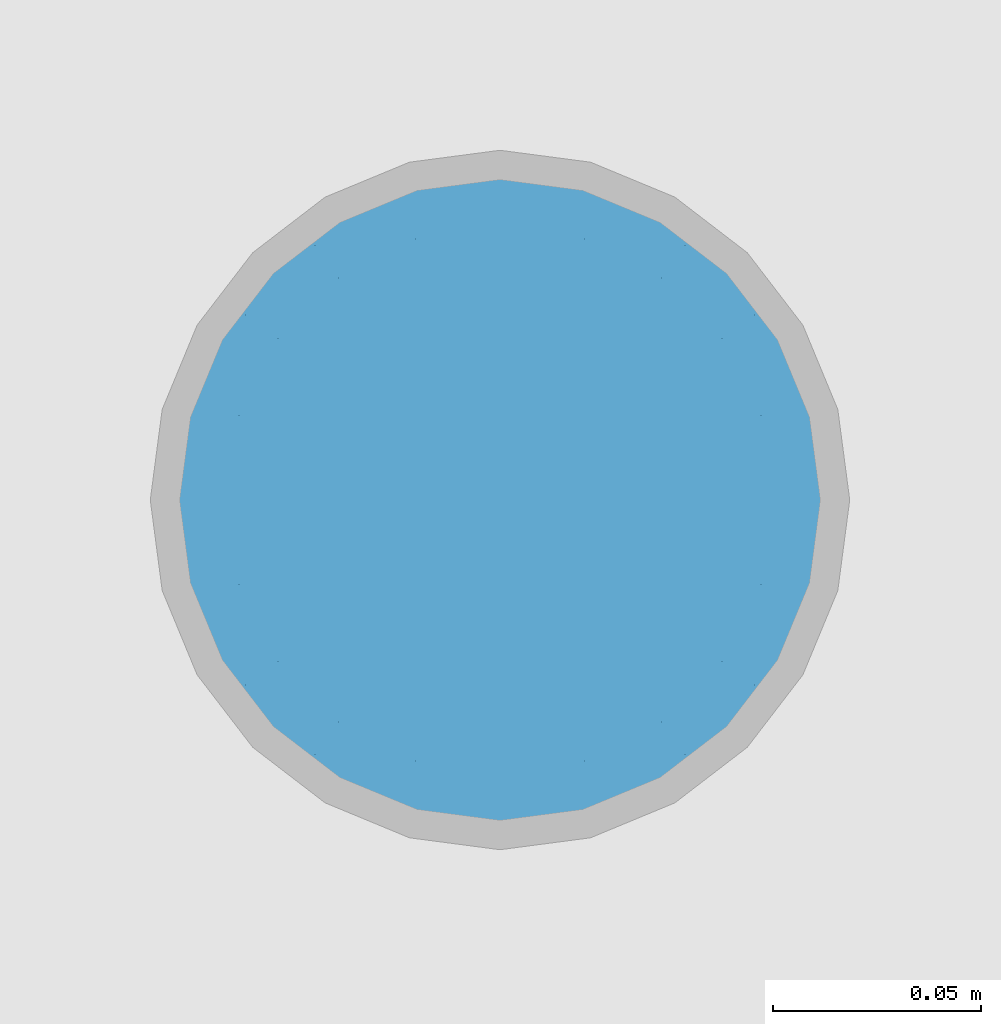
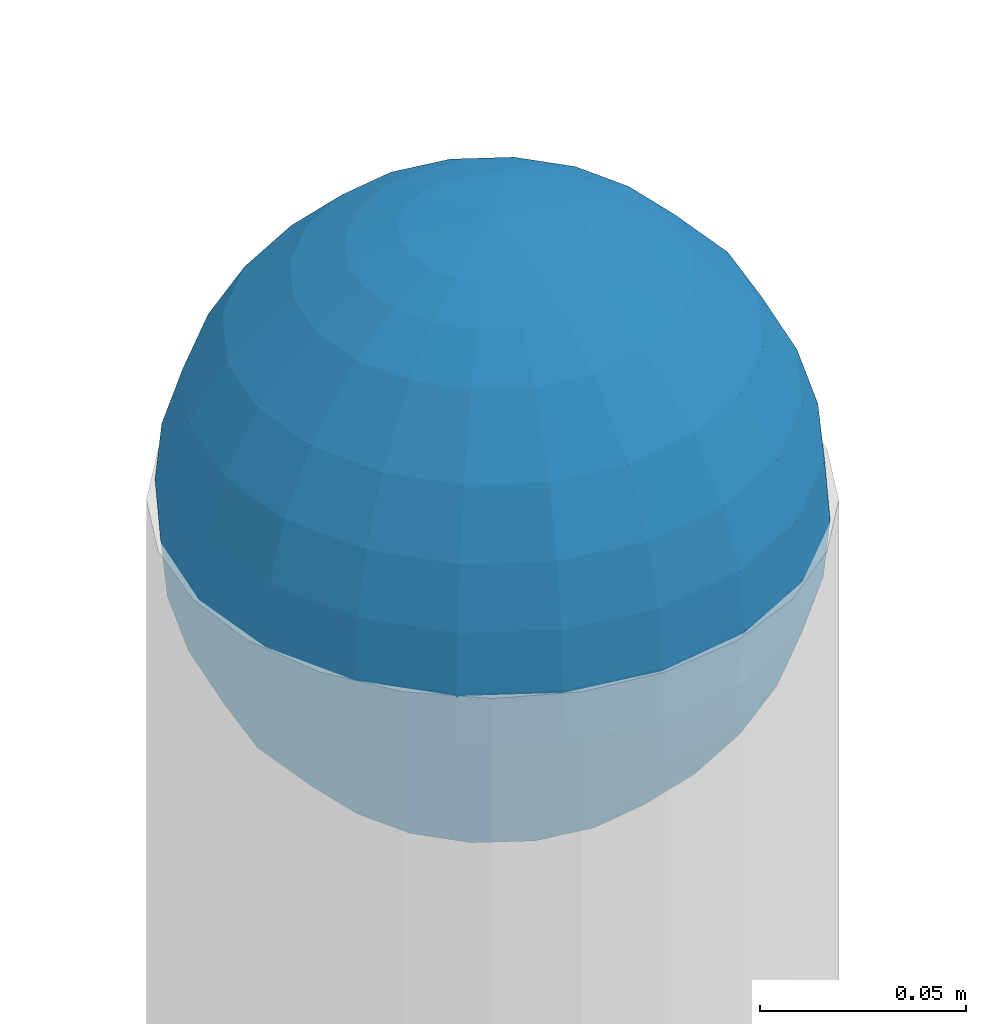
# One storey, part 1545 of 3843: 1 column, 1 element without a shape of its own.
"""IFC2X3 building model written with IfcOpenShell, lengths in millimetres."""

from ifc_helpers import new_model, si_unit, frame, origin_with_axes, place, context, subcontext, project, spatial, faceted_brep, material, type_object, element, aggregate, save


model = new_model("IFC2X3")

# Units and contexts
model_context = context("Model", 3, precision=1e-05, world=origin_with_axes())
body_context = subcontext(model_context, "Body", "Model", "MODEL_VIEW")
ifc_project = project(units=[si_unit("LENGTHUNIT", "METRE", prefix="MILLI"), si_unit("AREAUNIT", "SQUARE_METRE"), si_unit("VOLUMEUNIT", "CUBIC_METRE"), si_unit("MASSUNIT", "GRAM", prefix="KILO"), si_unit("TIMEUNIT", "SECOND"), si_unit("PLANEANGLEUNIT", "RADIAN"), si_unit("SOLIDANGLEUNIT", "STERADIAN"), si_unit("THERMODYNAMICTEMPERATUREUNIT", "DEGREE_CELSIUS"), si_unit("LUMINOUSINTENSITYUNIT", "LUMEN")], contexts=[model_context])

# Site, building, storey
site_placement = place(None, origin_with_axes())
site = spatial("IfcSite", under=ifc_project, at=site_placement, CompositionType="ELEMENT")
building_placement = place(site_placement, origin_with_axes())
building = spatial("IfcBuilding", under=site, at=building_placement, Name="Undefined", CompositionType="ELEMENT")
storey_placement = place(building_placement, origin_with_axes())
storey = spatial("IfcBuildingStorey", under=building, at=storey_placement, Name="Undefined", CompositionType="ELEMENT", Elevation=0.0)

# Assembly, column
assembly_placement = place(storey_placement, origin_with_axes())
assembly = element("IfcElementAssembly", 1, at=assembly_placement, inside=storey, Name="CONC. FILL", AssemblyPlace="NOTDEFINED", PredefinedType="REINFORCEMENT_UNIT")
ifc_material = material(Name="CONCRETE/1500")
column_type = type_object("IfcColumnType", PredefinedType="NOTDEFINED")
column_placement = place(assembly_placement, frame((15156.5818631947, 73392.460174799, 31411.8625), z_axis=(-1.0, 0.0, 0.0), x_axis=(0.0, 0.0, 1.0)))
column = element("IfcColumn", 2, at=column_placement, type_object=column_type, material=ifc_material, Name="CONC. FILL", context=body_context, shape_type="Brep", body=[
    faceted_brep([(0.0, 0.0, 2.0), (0.0, -0.619999999995343, 1.89999999999964), (3.36549999999988, -7.1422259999963, 21.9814139999999), (3.36549999999988, 0.0, 23.1139999999996), (0.0, -1.17999999999302, 1.6200000000008), (3.36549999999988, -13.5910319999966, 18.6992260000006), (0.0, -1.61999999999534, 1.18000000000029), (3.36549999999988, -18.699225999997, 13.5910320000003), (0.0, -1.89999999999418, 0.6200000000008), (3.36549999999988, -21.9814139999944, 7.14222599999994), (0.0, -2.0, 0.0), (3.36549999999988, -23.1140000000014, 0.0), (0.0, -1.89999999999418, -0.6200000000008), (3.36549999999988, -21.9814139999944, -7.14222599999994), (0.0, -1.61999999999534, -1.18000000000029), (3.36549999999988, -18.699225999997, -13.5910320000003), (0.0, -1.17999999999302, -1.6200000000008), (3.36549999999988, -13.5910319999966, -18.6992260000006), (0.0, -0.619999999995343, -1.89999999999964), (3.36549999999988, -7.1422259999963, -21.9814139999999), (0.0, 0.0, -2.0), (3.36549999999988, 0.0, -23.1139999999996), (0.0, 0.619999999995343, -1.89999999999964), (3.36549999999988, 7.1422259999963, -21.9814139999999), (0.0, 1.17999999999302, -1.6200000000008), (3.36549999999988, 13.5910319999966, -18.6992260000006), (0.0, 1.61999999999534, -1.18000000000029), (3.36549999999988, 18.699225999997, -13.5910320000003), (0.0, 1.89999999999418, -0.6200000000008), (3.36549999999988, 21.9814139999944, -7.14222599999994), (0.0, 2.0, 0.0), (3.36549999999988, 23.1140000000014, 0.0), (0.0, 1.89999999999418, 0.6200000000008), (3.36549999999988, 21.9814139999944, 7.14222599999994), (0.0, 1.61999999999534, 1.18000000000029), (3.36549999999988, 18.699225999997, 13.5910320000003), (0.0, 1.17999999999302, 1.6200000000008), (3.36549999999988, 13.5910319999966, 18.6992260000006), (0.0, 0.619999999995343, 1.89999999999964), (3.36549999999988, 7.1422259999963, 21.9814139999999), (8.41374999999971, -11.1214661999984, 34.2282018000005), (8.41374999999971, 0.0, 35.9917999999998), (8.41374999999971, -21.1631784000056, 29.1173662000001), (8.41374999999971, -29.1173661999928, 21.1631784000001), (8.41374999999971, -34.2282017999969, 11.1214662000002), (8.41374999999971, -35.9918000000034, 0.0), (8.41374999999971, -34.2282017999969, -11.1214662000002), (8.41374999999971, -29.1173661999928, -21.1631784000001), (8.41374999999971, -21.1631784000056, -29.1173662000001), (8.41374999999971, -11.1214661999984, -34.2282018000005), (8.41374999999971, 0.0, -35.9917999999998), (8.41374999999971, 11.1214661999984, -34.2282018000005), (8.41374999999971, 21.1631784000056, -29.1173662000001), (8.41374999999971, 29.1173661999928, -21.1631784000001), (8.41374999999971, 34.2282017999969, -11.1214662000002), (8.41374999999971, 35.9918000000034, 0.0), (8.41374999999971, 34.2282017999969, 11.1214662000002), (8.41374999999971, 29.1173661999928, 21.1631784000001), (8.41374999999971, 21.1631784000056, 29.1173662000001), (8.41374999999971, 11.1214661999984, 34.2282018000005), (16.8274999999994, -15.3047700000025, 47.1030300000002), (16.8274999999994, 0.0, 49.5300000000007), (16.8274999999994, -29.1236400000053, 40.0697700000001), (16.8274999999994, -40.0697700000019, 29.1236399999998), (16.8274999999994, -47.1030299999984, 15.3047700000006), (16.8274999999994, -49.5299999999988, 0.0), (16.8274999999994, -47.1030299999984, -15.3047700000006), (16.8274999999994, -40.0697700000019, -29.1236399999998), (16.8274999999994, -29.1236400000053, -40.0697700000001), (16.8274999999994, -15.3047700000025, -47.1030300000002), (16.8274999999994, 0.0, -49.5300000000007), (16.8274999999994, 15.3047700000025, -47.1030300000002), (16.8274999999994, 29.1236400000053, -40.0697700000001), (16.8274999999994, 40.0697700000019, -29.1236399999998), (16.8274999999994, 47.1030299999984, -15.3047700000006), (16.8274999999994, 49.5299999999988, 0.0), (16.8274999999994, 47.1030299999984, 15.3047700000006), (16.8274999999994, 40.0697700000019, 29.1236399999998), (16.8274999999994, 29.1236400000053, 40.0697700000001), (16.8274999999994, 15.3047700000025, 47.1030300000002), (33.6549999999988, -20.4063599999936, 62.8040400000009), (33.6549999999988, 0.0, 66.0400000000009), (33.6549999999988, -38.831520000007, 53.4263599999995), (33.6549999999988, -53.4263599999977, 38.8315199999997), (33.6549999999988, -62.8040400000027, 20.4063600000009), (33.6549999999988, -66.0399999999936, 0.0), (33.6549999999988, -62.8040400000027, -20.4063600000009), (33.6549999999988, -53.4263599999977, -38.8315199999997), (33.6549999999988, -38.831520000007, -53.4263599999995), (33.6549999999988, -20.4063599999936, -62.8040400000009), (33.6549999999988, 0.0, -66.0400000000009), (33.6549999999988, 20.4063599999936, -62.8040400000009), (33.6549999999988, 38.831520000007, -53.4263599999995), (33.6549999999988, 53.4263599999977, -38.8315199999997), (33.6549999999988, 62.8040400000027, -20.4063600000009), (33.6549999999988, 66.0399999999936, 0.0), (33.6549999999988, 62.8040400000027, 20.4063600000009), (33.6549999999988, 53.4263599999977, 38.8315199999997), (33.6549999999988, 38.831520000007, 53.4263599999995), (33.6549999999988, 20.4063599999936, 62.8040400000009), (50.4824999999983, -23.3907901500061, 71.9891308499991), (50.4824999999983, 0.0, 75.6983500000006), (50.4824999999983, -44.5106298000028, 61.23996515), (50.4824999999983, -61.2399651500018, 44.5106297999992), (50.4824999999983, -71.9891308499937, 23.3907901500006), (50.4824999999983, -75.698350000006, 0.0), (50.4824999999983, -71.9891308499937, -23.3907901500006), (50.4824999999983, -61.2399651500018, -44.5106297999992), (50.4824999999983, -44.5106298000028, -61.23996515), (50.4824999999983, -23.3907901500061, -71.9891308499991), (50.4824999999983, 0.0, -75.6983500000006), (50.4824999999983, 23.3907901500061, -71.9891308499991), (50.4824999999983, 44.5106298000028, -61.23996515), (50.4824999999983, 61.2399651500018, -44.5106297999992), (50.4824999999983, 71.9891308499937, -23.3907901500006), (50.4824999999983, 75.698350000006, 0.0), (50.4824999999983, 71.9891308499937, 23.3907901500006), (50.4824999999983, 61.2399651500018, 44.5106297999992), (50.4824999999983, 44.5106298000028, 61.23996515), (50.4824999999983, 23.3907901500061, 71.9891308499991), (67.3099999999977, -24.9977910000016, 76.9349490000004), (67.3099999999977, 0.0, 80.8989999999994), (67.3099999999977, -47.5686120000028, 65.4472910000004), (67.3099999999977, -65.447291000004, 47.5686119999991), (67.3099999999977, -76.9349490000022, 24.9977909999998), (67.3099999999977, -80.8990000000049, 0.0), (67.3099999999977, -76.9349490000022, -24.9977909999998), (67.3099999999977, -65.447291000004, -47.5686119999991), (67.3099999999977, -47.5686120000028, -65.4472910000004), (67.3099999999977, -24.9977910000016, -76.9349490000004), (67.3099999999977, 0.0, -80.8989999999994), (67.3099999999977, 24.9977910000016, -76.9349490000004), (67.3099999999977, 47.5686120000028, -65.4472910000004), (67.3099999999977, 65.447291000004, -47.5686119999991), (67.3099999999977, 76.9349490000022, -24.9977909999998), (67.3099999999977, 80.8990000000049, 0.0), (67.3099999999977, 76.9349490000022, 24.9977909999998), (67.3099999999977, 65.447291000004, 47.5686119999991), (67.3099999999977, 47.5686120000028, 65.4472910000004), (67.3099999999977, 24.9977910000016, 76.9349490000004), (84.1374999999935, -25.5079499999993, 78.5050499999998), (84.1374999999935, 0.0, 82.5499999999993), (84.1374999999935, -48.5393999999942, 66.7829500000007), (84.1374999999935, -66.7829499999934, 48.5393999999997), (84.1374999999935, -78.505050000007, 25.5079499999993), (84.1374999999935, -82.5500000000029, 0.0), (84.1374999999935, -78.505050000007, -25.5079499999993), (84.1374999999935, -66.7829499999934, -48.5393999999997), (84.1374999999935, -48.5393999999942, -66.7829500000007), (84.1374999999935, -25.5079499999993, -78.5050499999998), (84.1374999999935, 0.0, -82.5499999999993), (84.1374999999935, 25.5079499999993, -78.5050499999998), (84.1374999999935, 48.5393999999942, -66.7829500000007), (84.1374999999935, 66.7829499999934, -48.5393999999997), (84.1374999999935, 78.505050000007, -25.5079499999993), (84.1374999999935, 82.5500000000029, 0.0), (84.1374999999935, 78.505050000007, 25.5079499999993), (84.1374999999935, 66.7829499999934, 48.5393999999997), (84.1374999999935, 48.5393999999942, 66.7829500000007), (84.1374999999935, 25.5079499999993, 78.5050499999998), (100.964999999993, -24.9977910000016, 76.9349490000004), (100.964999999993, 0.0, 80.8989999999994), (100.964999999993, -47.5686120000028, 65.4472910000004), (100.964999999993, -65.447291000004, 47.5686119999991), (100.964999999993, -76.9349490000022, 24.9977909999998), (100.964999999993, -80.8990000000049, 0.0), (100.964999999993, -76.9349490000022, -24.9977909999998), (100.964999999993, -65.447291000004, -47.5686119999991), (100.964999999993, -47.5686120000028, -65.4472910000004), (100.964999999993, -24.9977910000016, -76.9349490000004), (100.964999999993, 0.0, -80.8989999999994), (100.964999999993, 24.9977910000016, -76.9349490000004), (100.964999999993, 47.5686120000028, -65.4472910000004), (100.964999999993, 65.447291000004, -47.5686119999991), (100.964999999993, 76.9349490000022, -24.9977909999998), (100.964999999993, 80.8990000000049, 0.0), (100.964999999993, 76.9349490000022, 24.9977909999998), (100.964999999993, 65.447291000004, 47.5686119999991), (100.964999999993, 47.5686120000028, 65.4472910000004), (100.964999999993, 24.9977910000016, 76.9349490000004), (117.792499999992, -23.3907901500061, 71.9891308499991), (117.792499999992, 0.0, 75.6983500000006), (117.792499999992, -44.5106298000028, 61.23996515), (117.792499999992, -61.2399651500018, 44.5106297999992), (117.792499999992, -71.9891308499937, 23.3907901500006), (117.792499999992, -75.698350000006, 0.0), (117.792499999992, -71.9891308499937, -23.3907901500006), (117.792499999992, -61.2399651500018, -44.5106297999992), (117.792499999992, -44.5106298000028, -61.23996515), (117.792499999992, -23.3907901500061, -71.9891308499991), (117.792499999992, 0.0, -75.6983500000006), (117.792499999992, 23.3907901500061, -71.9891308499991), (117.792499999992, 44.5106298000028, -61.23996515), (117.792499999992, 61.2399651500018, -44.5106297999992), (117.792499999992, 71.9891308499937, -23.3907901500006), (117.792499999992, 75.698350000006, 0.0), (117.792499999992, 71.9891308499937, 23.3907901500006), (117.792499999992, 61.2399651500018, 44.5106297999992), (117.792499999992, 44.5106298000028, 61.23996515), (117.792499999992, 23.3907901500061, 71.9891308499991), (134.619999999992, -20.4063599999936, 62.8040400000009), (134.619999999992, 0.0, 66.0400000000009), (134.619999999992, -38.831520000007, 53.4263599999995), (134.619999999992, -53.4263599999977, 38.8315199999997), (134.619999999992, -62.8040400000027, 20.4063600000009), (134.619999999992, -66.0399999999936, 0.0), (134.619999999992, -62.8040400000027, -20.4063600000009), (134.619999999992, -53.4263599999977, -38.8315199999997), (134.619999999992, -38.831520000007, -53.4263599999995), (134.619999999992, -20.4063599999936, -62.8040400000009), (134.619999999992, 0.0, -66.0400000000009), (134.619999999992, 20.4063599999936, -62.8040400000009), (134.619999999992, 38.831520000007, -53.4263599999995), (134.619999999992, 53.4263599999977, -38.8315199999997), (134.619999999992, 62.8040400000027, -20.4063600000009), (134.619999999992, 66.0399999999936, 0.0), (134.619999999992, 62.8040400000027, 20.4063600000009), (134.619999999992, 53.4263599999977, 38.8315199999997), (134.619999999992, 38.831520000007, 53.4263599999995), (134.619999999992, 20.4063599999936, 62.8040400000009), (151.447499999991, -15.3047700000025, 47.1030300000002), (151.447499999991, 0.0, 49.5300000000007), (151.447499999991, -29.1236400000053, 40.0697700000001), (151.447499999991, -40.0697700000019, 29.1236399999998), (151.447499999991, -47.1030299999984, 15.3047700000006), (151.447499999991, -49.5299999999988, 0.0), (151.447499999991, -47.1030299999984, -15.3047700000006), (151.447499999991, -40.0697700000019, -29.1236399999998), (151.447499999991, -29.1236400000053, -40.0697700000001), (151.447499999991, -15.3047700000025, -47.1030300000002), (151.447499999991, 0.0, -49.5300000000007), (151.447499999991, 15.3047700000025, -47.1030300000002), (151.447499999991, 29.1236400000053, -40.0697700000001), (151.447499999991, 40.0697700000019, -29.1236399999998), (151.447499999991, 47.1030299999984, -15.3047700000006), (151.447499999991, 49.5299999999988, 0.0), (151.447499999991, 47.1030299999984, 15.3047700000006), (151.447499999991, 40.0697700000019, 29.1236399999998), (151.447499999991, 29.1236400000053, 40.0697700000001), (151.447499999991, 15.3047700000025, 47.1030300000002), (159.861249999991, -11.1214661999984, 34.2282018000005), (159.861249999991, 0.0, 35.9917999999998), (159.861249999991, -21.1631784000056, 29.1173662000001), (159.861249999991, -29.1173661999928, 21.1631784000001), (159.861249999991, -34.2282017999969, 11.1214662000002), (159.861249999991, -35.9918000000034, 0.0), (159.861249999991, -34.2282017999969, -11.1214662000002), (159.861249999991, -29.1173661999928, -21.1631784000001), (159.861249999991, -21.1631784000056, -29.1173662000001), (159.861249999991, -11.1214661999984, -34.2282018000005), (159.861249999991, 0.0, -35.9917999999998), (159.861249999991, 11.1214661999984, -34.2282018000005), (159.861249999991, 21.1631784000056, -29.1173662000001), (159.861249999991, 29.1173661999928, -21.1631784000001), (159.861249999991, 34.2282017999969, -11.1214662000002), (159.861249999991, 35.9918000000034, 0.0), (159.861249999991, 34.2282017999969, 11.1214662000002), (159.861249999991, 29.1173661999928, 21.1631784000001), (159.861249999991, 21.1631784000056, 29.1173662000001), (159.861249999991, 11.1214661999984, 34.2282018000005), (164.909499999991, -7.1422259999963, 21.9814139999999), (164.909499999991, 0.0, 23.1139999999996), (164.909499999991, -13.5910319999966, 18.6992260000006), (164.909499999991, -18.699225999997, 13.5910320000003), (164.909499999991, -21.9814139999944, 7.14222599999994), (164.909499999991, -23.1140000000014, 0.0), (164.909499999991, -21.9814139999944, -7.14222599999994), (164.909499999991, -18.699225999997, -13.5910320000003), (164.909499999991, -13.5910319999966, -18.6992260000006), (164.909499999991, -7.1422259999963, -21.9814139999999), (164.909499999991, 0.0, -23.1139999999996), (164.909499999991, 7.1422259999963, -21.9814139999999), (164.909499999991, 13.5910319999966, -18.6992260000006), (164.909499999991, 18.699225999997, -13.5910320000003), (164.909499999991, 21.9814139999944, -7.14222599999994), (164.909499999991, 23.1140000000014, 0.0), (164.909499999991, 21.9814139999944, 7.14222599999994), (164.909499999991, 18.699225999997, 13.5910320000003), (164.909499999991, 13.5910319999966, 18.6992260000006), (164.909499999991, 7.1422259999963, 21.9814139999999), (168.274999999991, -0.619999999995343, 1.89999999999964), (168.274999999991, 0.0, 2.0), (168.274999999991, -1.17999999999302, 1.6200000000008), (168.274999999991, -1.61999999999534, 1.18000000000029), (168.274999999991, -1.89999999999418, 0.6200000000008), (168.274999999991, -2.0, 0.0), (168.274999999991, -1.89999999999418, -0.6200000000008), (168.274999999991, -1.61999999999534, -1.18000000000029), (168.274999999991, -1.17999999999302, -1.6200000000008), (168.274999999991, -0.619999999995343, -1.89999999999964), (168.274999999991, 0.0, -2.0), (168.274999999991, 0.619999999995343, -1.89999999999964), (168.274999999991, 1.17999999999302, -1.6200000000008), (168.274999999991, 1.61999999999534, -1.18000000000029), (168.274999999991, 1.89999999999418, -0.6200000000008), (168.274999999991, 2.0, 0.0), (168.274999999991, 1.89999999999418, 0.6200000000008), (168.274999999991, 1.61999999999534, 1.18000000000029), (168.274999999991, 1.17999999999302, 1.6200000000008), (168.274999999991, 0.619999999995343, 1.89999999999964)], [[[0, 1, 2, 3]], [[1, 4, 5, 2]], [[4, 6, 7, 5]], [[6, 8, 9, 7]], [[8, 10, 11, 9]], [[10, 12, 13, 11]], [[12, 14, 15, 13]], [[14, 16, 17, 15]], [[16, 18, 19, 17]], [[18, 20, 21, 19]], [[20, 22, 23, 21]], [[22, 24, 25, 23]], [[24, 26, 27, 25]], [[26, 28, 29, 27]], [[28, 30, 31, 29]], [[30, 32, 33, 31]], [[32, 34, 35, 33]], [[34, 36, 37, 35]], [[36, 38, 39, 37]], [[38, 0, 3, 39]], [[38, 36, 34, 32, 30, 28, 26, 24, 22, 20, 18, 16, 14, 12, 10, 8, 6, 4, 1, 0]], [[3, 2, 40, 41]], [[2, 5, 42, 40]], [[5, 7, 43, 42]], [[7, 9, 44, 43]], [[9, 11, 45, 44]], [[11, 13, 46, 45]], [[13, 15, 47, 46]], [[15, 17, 48, 47]], [[17, 19, 49, 48]], [[19, 21, 50, 49]], [[21, 23, 51, 50]], [[23, 25, 52, 51]], [[25, 27, 53, 52]], [[27, 29, 54, 53]], [[29, 31, 55, 54]], [[31, 33, 56, 55]], [[33, 35, 57, 56]], [[35, 37, 58, 57]], [[37, 39, 59, 58]], [[39, 3, 41, 59]], [[41, 40, 60, 61]], [[40, 42, 62, 60]], [[42, 43, 63, 62]], [[43, 44, 64, 63]], [[44, 45, 65, 64]], [[45, 46, 66, 65]], [[46, 47, 67, 66]], [[47, 48, 68, 67]], [[48, 49, 69, 68]], [[49, 50, 70, 69]], [[50, 51, 71, 70]], [[51, 52, 72, 71]], [[52, 53, 73, 72]], [[53, 54, 74, 73]], [[54, 55, 75, 74]], [[55, 56, 76, 75]], [[56, 57, 77, 76]], [[57, 58, 78, 77]], [[58, 59, 79, 78]], [[59, 41, 61, 79]], [[61, 60, 80, 81]], [[60, 62, 82, 80]], [[62, 63, 83, 82]], [[63, 64, 84, 83]], [[64, 65, 85, 84]], [[65, 66, 86, 85]], [[66, 67, 87, 86]], [[67, 68, 88, 87]], [[68, 69, 89, 88]], [[69, 70, 90, 89]], [[70, 71, 91, 90]], [[71, 72, 92, 91]], [[72, 73, 93, 92]], [[73, 74, 94, 93]], [[74, 75, 95, 94]], [[75, 76, 96, 95]], [[76, 77, 97, 96]], [[77, 78, 98, 97]], [[78, 79, 99, 98]], [[79, 61, 81, 99]], [[81, 80, 100, 101]], [[80, 82, 102, 100]], [[82, 83, 103, 102]], [[83, 84, 104, 103]], [[84, 85, 105, 104]], [[85, 86, 106, 105]], [[86, 87, 107, 106]], [[87, 88, 108, 107]], [[88, 89, 109, 108]], [[89, 90, 110, 109]], [[90, 91, 111, 110]], [[91, 92, 112, 111]], [[92, 93, 113, 112]], [[93, 94, 114, 113]], [[94, 95, 115, 114]], [[95, 96, 116, 115]], [[96, 97, 117, 116]], [[97, 98, 118, 117]], [[98, 99, 119, 118]], [[99, 81, 101, 119]], [[101, 100, 120, 121]], [[100, 102, 122, 120]], [[102, 103, 123, 122]], [[103, 104, 124, 123]], [[104, 105, 125, 124]], [[105, 106, 126, 125]], [[106, 107, 127, 126]], [[107, 108, 128, 127]], [[108, 109, 129, 128]], [[109, 110, 130, 129]], [[110, 111, 131, 130]], [[111, 112, 132, 131]], [[112, 113, 133, 132]], [[113, 114, 134, 133]], [[114, 115, 135, 134]], [[115, 116, 136, 135]], [[116, 117, 137, 136]], [[117, 118, 138, 137]], [[118, 119, 139, 138]], [[119, 101, 121, 139]], [[121, 120, 140, 141]], [[120, 122, 142, 140]], [[122, 123, 143, 142]], [[123, 124, 144, 143]], [[124, 125, 145, 144]], [[125, 126, 146, 145]], [[126, 127, 147, 146]], [[127, 128, 148, 147]], [[128, 129, 149, 148]], [[129, 130, 150, 149]], [[130, 131, 151, 150]], [[131, 132, 152, 151]], [[132, 133, 153, 152]], [[133, 134, 154, 153]], [[134, 135, 155, 154]], [[135, 136, 156, 155]], [[136, 137, 157, 156]], [[137, 138, 158, 157]], [[138, 139, 159, 158]], [[139, 121, 141, 159]], [[141, 140, 160, 161]], [[140, 142, 162, 160]], [[142, 143, 163, 162]], [[143, 144, 164, 163]], [[144, 145, 165, 164]], [[145, 146, 166, 165]], [[146, 147, 167, 166]], [[147, 148, 168, 167]], [[148, 149, 169, 168]], [[149, 150, 170, 169]], [[150, 151, 171, 170]], [[151, 152, 172, 171]], [[152, 153, 173, 172]], [[153, 154, 174, 173]], [[154, 155, 175, 174]], [[155, 156, 176, 175]], [[156, 157, 177, 176]], [[157, 158, 178, 177]], [[158, 159, 179, 178]], [[159, 141, 161, 179]], [[161, 160, 180, 181]], [[160, 162, 182, 180]], [[162, 163, 183, 182]], [[163, 164, 184, 183]], [[164, 165, 185, 184]], [[165, 166, 186, 185]], [[166, 167, 187, 186]], [[167, 168, 188, 187]], [[168, 169, 189, 188]], [[169, 170, 190, 189]], [[170, 171, 191, 190]], [[171, 172, 192, 191]], [[172, 173, 193, 192]], [[173, 174, 194, 193]], [[174, 175, 195, 194]], [[175, 176, 196, 195]], [[176, 177, 197, 196]], [[177, 178, 198, 197]], [[178, 179, 199, 198]], [[179, 161, 181, 199]], [[181, 180, 200, 201]], [[180, 182, 202, 200]], [[182, 183, 203, 202]], [[183, 184, 204, 203]], [[184, 185, 205, 204]], [[185, 186, 206, 205]], [[186, 187, 207, 206]], [[187, 188, 208, 207]], [[188, 189, 209, 208]], [[189, 190, 210, 209]], [[190, 191, 211, 210]], [[191, 192, 212, 211]], [[192, 193, 213, 212]], [[193, 194, 214, 213]], [[194, 195, 215, 214]], [[195, 196, 216, 215]], [[196, 197, 217, 216]], [[197, 198, 218, 217]], [[198, 199, 219, 218]], [[199, 181, 201, 219]], [[201, 200, 220, 221]], [[200, 202, 222, 220]], [[202, 203, 223, 222]], [[203, 204, 224, 223]], [[204, 205, 225, 224]], [[205, 206, 226, 225]], [[206, 207, 227, 226]], [[207, 208, 228, 227]], [[208, 209, 229, 228]], [[209, 210, 230, 229]], [[210, 211, 231, 230]], [[211, 212, 232, 231]], [[212, 213, 233, 232]], [[213, 214, 234, 233]], [[214, 215, 235, 234]], [[215, 216, 236, 235]], [[216, 217, 237, 236]], [[217, 218, 238, 237]], [[218, 219, 239, 238]], [[219, 201, 221, 239]], [[221, 220, 240, 241]], [[220, 222, 242, 240]], [[222, 223, 243, 242]], [[223, 224, 244, 243]], [[224, 225, 245, 244]], [[225, 226, 246, 245]], [[226, 227, 247, 246]], [[227, 228, 248, 247]], [[228, 229, 249, 248]], [[229, 230, 250, 249]], [[230, 231, 251, 250]], [[231, 232, 252, 251]], [[232, 233, 253, 252]], [[233, 234, 254, 253]], [[234, 235, 255, 254]], [[235, 236, 256, 255]], [[236, 237, 257, 256]], [[237, 238, 258, 257]], [[238, 239, 259, 258]], [[239, 221, 241, 259]], [[241, 240, 260, 261]], [[240, 242, 262, 260]], [[242, 243, 263, 262]], [[243, 244, 264, 263]], [[244, 245, 265, 264]], [[245, 246, 266, 265]], [[246, 247, 267, 266]], [[247, 248, 268, 267]], [[248, 249, 269, 268]], [[249, 250, 270, 269]], [[250, 251, 271, 270]], [[251, 252, 272, 271]], [[252, 253, 273, 272]], [[253, 254, 274, 273]], [[254, 255, 275, 274]], [[255, 256, 276, 275]], [[256, 257, 277, 276]], [[257, 258, 278, 277]], [[258, 259, 279, 278]], [[259, 241, 261, 279]], [[261, 260, 280, 281]], [[260, 262, 282, 280]], [[262, 263, 283, 282]], [[263, 264, 284, 283]], [[264, 265, 285, 284]], [[265, 266, 286, 285]], [[266, 267, 287, 286]], [[267, 268, 288, 287]], [[268, 269, 289, 288]], [[269, 270, 290, 289]], [[270, 271, 291, 290]], [[271, 272, 292, 291]], [[272, 273, 293, 292]], [[273, 274, 294, 293]], [[274, 275, 295, 294]], [[275, 276, 296, 295]], [[276, 277, 297, 296]], [[277, 278, 298, 297]], [[278, 279, 299, 298]], [[279, 261, 281, 299]], [[282, 283, 284, 285, 286, 287, 288, 289, 290, 291, 292, 293, 294, 295, 296, 297, 298, 299, 281, 280]]]),
])
aggregate(assembly, [column])

save(model, "model.ifc")
